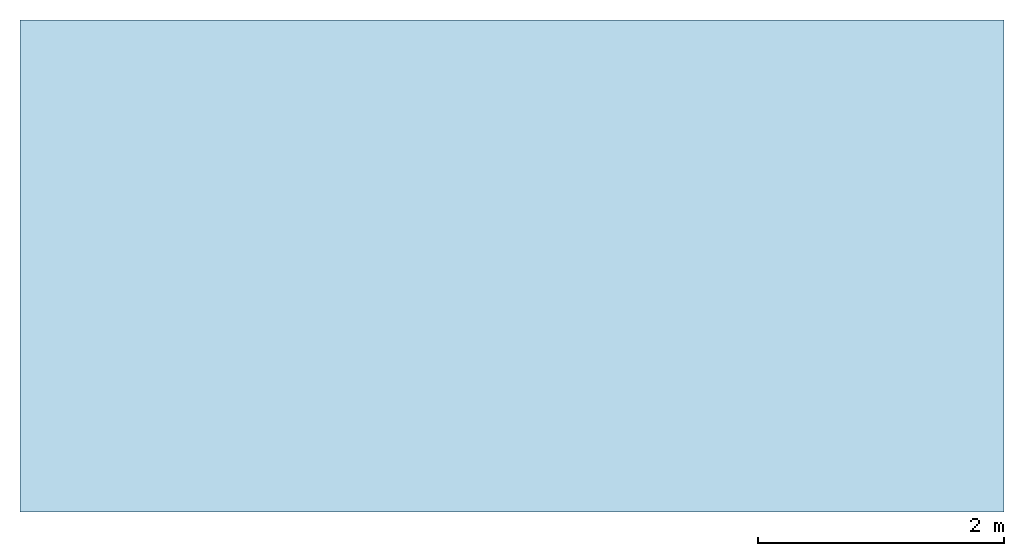
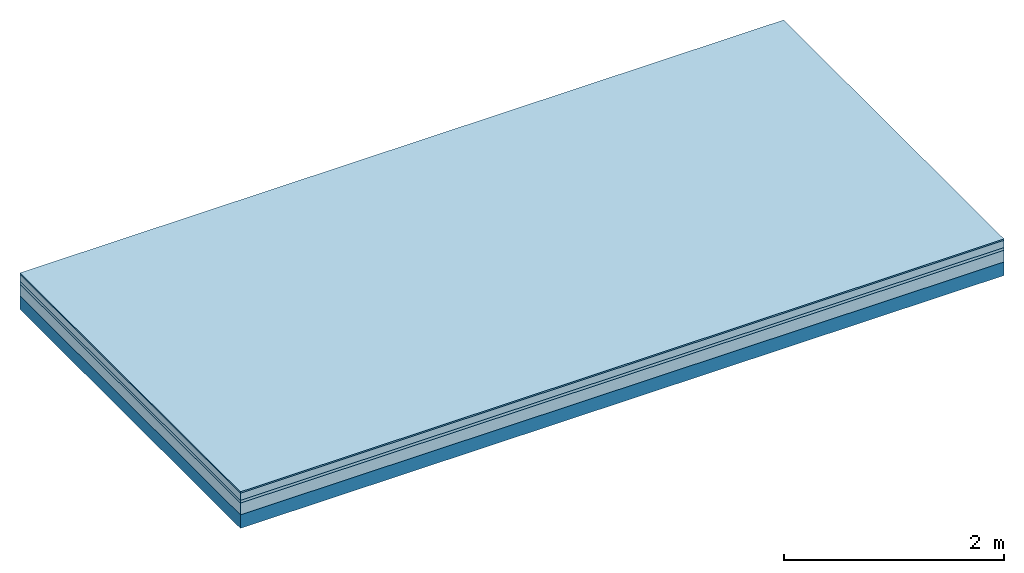
# One storey: 4 plates, 1 member, 1 element without a shape of its own.
"""IFC4 building model written with IfcOpenShell, lengths in metres."""

from ifc_helpers import new_model, si_unit, derived_unit, direction, frame, frame_2d, origin, origin_with_axes, place, context, project, spatial, rectangle, extrude, material, layer, layer_set, type_object, element, aggregate, save


model = new_model("IFC4")

# Units and contexts
plan_context = context("Plan", 3, precision=1e-05, world=origin(), true_north=direction((0.0, 1.0)))
model_context = context("Model", 3, precision=1e-05, world=origin(), true_north=direction((0.0, 1.0)))
ifc_project = project(units=[si_unit("LENGTHUNIT", "METRE"), derived_unit("SOUNDPRESSUREUNIT", [(si_unit("PRESSUREUNIT", "PASCAL", prefix="MICRO"), 0)]), si_unit("ENERGYUNIT", "JOULE", prefix="MEGA"), si_unit("MASSUNIT", "GRAM", prefix="KILO"), derived_unit("THERMALTRANSMITTANCEUNIT", [(si_unit("POWERUNIT", "WATT"), 1), (si_unit("AREAUNIT", "SQUARE_METRE"), -1), (si_unit("THERMODYNAMICTEMPERATUREUNIT", "KELVIN"), -1)]), derived_unit("AREADENSITYUNIT", [(si_unit("MASSUNIT", "GRAM", prefix="KILO"), 1), (si_unit("AREAUNIT", "SQUARE_METRE"), -1)]), derived_unit("USERDEFINED", [(si_unit("ENERGYUNIT", "JOULE", prefix="MEGA"), 1), (si_unit("AREAUNIT", "SQUARE_METRE"), -1)])], contexts=[plan_context, model_context])

# Site, building, storey
site = spatial("IfcSite", under=ifc_project)
building_placement = place(None, origin())
building = spatial("IfcBuilding", under=site, at=building_placement)
storey_placement = place(building_placement, origin())
storey = spatial("IfcBuildingStorey", under=building, at=storey_placement)

# Slab, member, plates
ifc_material_1 = material(Category="11.013")
ifc_layer_1 = layer(ifc_material_1, 0.015, Name="Flooring")
ifc_material_2 = material(Name="Cement screed", Category="04.006")
ifc_layer_2 = layer(ifc_material_2, 0.08, Name="On-material")
ifc_material_3 = material(Name="Wood fiber generic product", Category="10.009")
ifc_layer_3 = layer(ifc_material_3, 0.03, Name="Impact sound insulation")
ifc_material_4 = material(Category="01.002")
ifc_layer_4 = layer(ifc_material_4, 0.13, Name="Sub-floor")
ifc_material_5 = material(Name="Rigid, of the art")
ifc_layer_5 = layer(ifc_material_5, 0.0, Name="Bond")
ifc_layer_6 = layer(None, 0.15, Name="Supporting structure")
ifc_layer_set = layer_set([ifc_layer_1, ifc_layer_2, ifc_layer_3, ifc_layer_4, ifc_layer_5, ifc_layer_6])
slab_type = type_object("IfcSlabType", Name="A2193", PredefinedType="NOTDEFINED", material=ifc_layer_set)
slab_placement = place(None, frame((0.0, 0.0, 0.0), z_axis=(0.0, 0.0, -1.0), x_axis=(1.0, 0.0, 0.0)))
slab = element("IfcSlab", 1, at=slab_placement, inside=storey, type_object=slab_type, material=ifc_layer_set, Name="Slab #1")
ifc_material_6 = material(Name="Solid timber panel")
member_placement = place(slab_placement, origin())
member = element("IfcMember", 2, at=member_placement, material=ifc_material_6, Name="Supporting structure", context=plan_context, shape_type="SweptSolid", body=[
    extrude(rectangle(XDim=1.0, YDim=0.15, at=frame_2d((0.5, 0.075), x_axis=(1.0, 0.0))), frame((0.0, 4.0, 0.255), z_axis=(0.0, -1.0, 0.0), x_axis=(1.0, 0.0, 0.0)), (0.0, 0.0, 1.0), 4.0),
    extrude(rectangle(XDim=1.0, YDim=0.15, at=frame_2d((0.5, 0.075), x_axis=(1.0, 0.0))), frame((1.0, 4.0, 0.255), z_axis=(0.0, -1.0, 0.0), x_axis=(1.0, 0.0, 0.0)), (0.0, 0.0, 1.0), 4.0),
    extrude(rectangle(XDim=1.0, YDim=0.15, at=frame_2d((0.5, 0.075), x_axis=(1.0, 0.0))), frame((2.0, 4.0, 0.255), z_axis=(0.0, -1.0, 0.0), x_axis=(1.0, 0.0, 0.0)), (0.0, 0.0, 1.0), 4.0),
    extrude(rectangle(XDim=1.0, YDim=0.15, at=frame_2d((0.5, 0.075), x_axis=(1.0, 0.0))), frame((3.0, 4.0, 0.255), z_axis=(0.0, -1.0, 0.0), x_axis=(1.0, 0.0, 0.0)), (0.0, 0.0, 1.0), 4.0),
    extrude(rectangle(XDim=1.0, YDim=0.15, at=frame_2d((0.5, 0.075), x_axis=(1.0, 0.0))), frame((4.0, 4.0, 0.255), z_axis=(0.0, -1.0, 0.0), x_axis=(1.0, 0.0, 0.0)), (0.0, 0.0, 1.0), 4.0),
    extrude(rectangle(XDim=1.0, YDim=0.15, at=frame_2d((0.5, 0.075), x_axis=(1.0, 0.0))), frame((5.0, 4.0, 0.255), z_axis=(0.0, -1.0, 0.0), x_axis=(1.0, 0.0, 0.0)), (0.0, 0.0, 1.0), 4.0),
    extrude(rectangle(XDim=1.0, YDim=0.15, at=frame_2d((0.5, 0.075), x_axis=(1.0, 0.0))), frame((6.0, 4.0, 0.255), z_axis=(0.0, -1.0, 0.0), x_axis=(1.0, 0.0, 0.0)), (0.0, 0.0, 1.0), 4.0),
    extrude(rectangle(XDim=1.0, YDim=0.15, at=frame_2d((0.5, 0.075), x_axis=(1.0, 0.0))), frame((7.0, 4.0, 0.255), z_axis=(0.0, -1.0, 0.0), x_axis=(1.0, 0.0, 0.0)), (0.0, 0.0, 1.0), 4.0),
])
plate_1_placement = place(slab_placement, origin())
plate_1 = element("IfcPlate", 3, at=plate_1_placement, material=ifc_material_1, Name="Flooring", context=plan_context, shape_type="SweptSolid", body=[
    extrude(rectangle(XDim=8.0, YDim=4.0, at=frame_2d((4.0, 2.0), x_axis=(1.0, 0.0))), origin_with_axes(), (0.0, 0.0, 1.0), 0.015),
])
plate_2_placement = place(slab_placement, origin())
plate_2 = element("IfcPlate", 4, at=plate_2_placement, material=ifc_material_2, Name="On-material", context=plan_context, shape_type="SweptSolid", body=[
    extrude(rectangle(XDim=8.0, YDim=4.0, at=frame_2d((4.0, 2.0), x_axis=(1.0, 0.0))), frame((0.0, 0.0, 0.015), z_axis=(0.0, 0.0, 1.0), x_axis=(1.0, 0.0, 0.0)), (0.0, 0.0, 1.0), 0.08),
])
plate_3_placement = place(slab_placement, origin())
plate_3 = element("IfcPlate", 5, at=plate_3_placement, material=ifc_material_3, Name="Impact sound insulation", context=plan_context, shape_type="SweptSolid", body=[
    extrude(rectangle(XDim=8.0, YDim=4.0, at=frame_2d((4.0, 2.0), x_axis=(1.0, 0.0))), frame((0.0, 0.0, 0.095), z_axis=(0.0, 0.0, 1.0), x_axis=(1.0, 0.0, 0.0)), (0.0, 0.0, 1.0), 0.03),
])
plate_4_placement = place(slab_placement, origin())
plate_4 = element("IfcPlate", 6, at=plate_4_placement, material=ifc_material_4, Name="Sub-floor", context=plan_context, shape_type="SweptSolid", body=[
    extrude(rectangle(XDim=8.0, YDim=4.0, at=frame_2d((4.0, 2.0), x_axis=(1.0, 0.0))), frame((0.0, 0.0, 0.125), z_axis=(0.0, 0.0, 1.0), x_axis=(1.0, 0.0, 0.0)), (0.0, 0.0, 1.0), 0.13),
])
aggregate(slab, [plate_1, plate_2, plate_3, plate_4, member])

save(model, "model.ifc")
